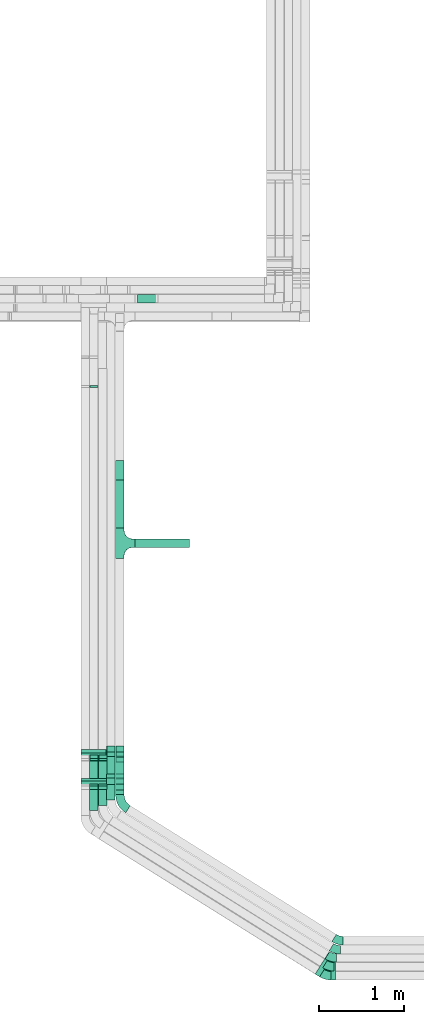
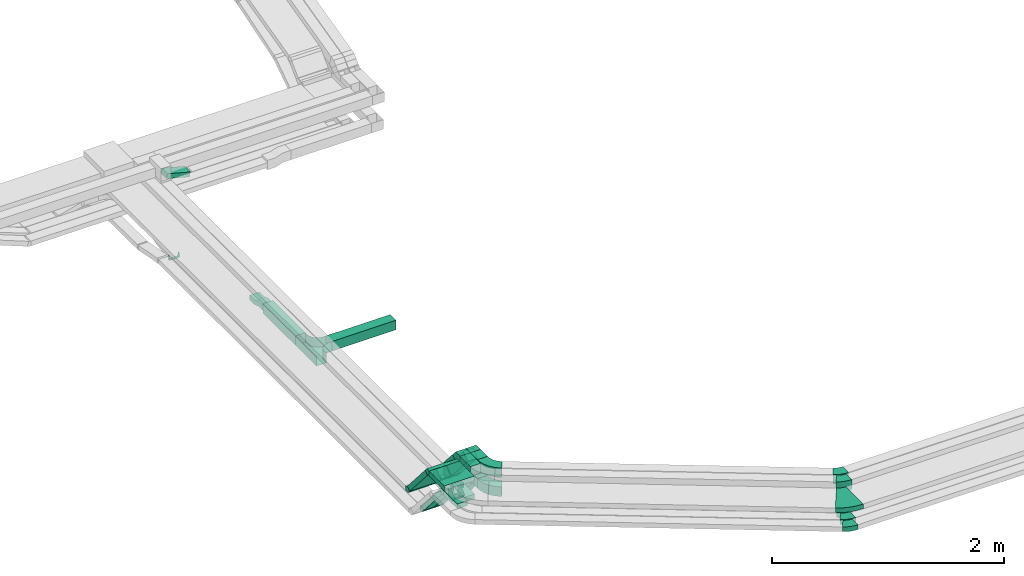
# One storey, part 4 of 14: 23 flow fittings, 15 flow segments.
"""IFC2X3 building model written with IfcOpenShell, lengths in millimetres."""

from ifc_helpers import new_model, entity, si_unit, converted_unit, derived_unit, direction, frame, frame_2d, origin, origin_2d_with_axis, place, context, subcontext, project, spatial, polyline, circle_curve, parameter, trimmed, segment, composite_curve, rectangle, outline, extrude, faceted_brep, source, transform, mapped, material, type_object, type_shapes, element, save


model = new_model("IFC2X3")

# Units and contexts
model_context = context("Model", 3, precision=0.01, world=origin(), true_north=direction((6.12303176911189e-17, 1.0)))
body_context = subcontext(model_context, "Body", "Model", "MODEL_VIEW")
ifc_project = project(units=[si_unit("LENGTHUNIT", "METRE", prefix="MILLI"), si_unit("AREAUNIT", "SQUARE_METRE"), si_unit("VOLUMEUNIT", "CUBIC_METRE"), converted_unit("PLANEANGLEUNIT", "DEGREE", entity("IfcRatioMeasure", 0.0174532925199433), si_unit("PLANEANGLEUNIT", "RADIAN"), dimensions=[0, 0, 0, 0, 0, 0, 0]), si_unit("MASSUNIT", "GRAM", prefix="KILO"), derived_unit("MASSDENSITYUNIT", [(si_unit("MASSUNIT", "GRAM", prefix="KILO"), 1), (si_unit("LENGTHUNIT", "METRE"), -3)]), derived_unit("MOMENTOFINERTIAUNIT", [(si_unit("LENGTHUNIT", "METRE"), 4)]), si_unit("TIMEUNIT", "SECOND"), si_unit("FREQUENCYUNIT", "HERTZ"), si_unit("THERMODYNAMICTEMPERATUREUNIT", "DEGREE_CELSIUS"), derived_unit("THERMALTRANSMITTANCEUNIT", [(si_unit("MASSUNIT", "GRAM", prefix="KILO"), 1), (si_unit("THERMODYNAMICTEMPERATUREUNIT", "KELVIN"), -1), (si_unit("TIMEUNIT", "SECOND"), -3)]), derived_unit("VOLUMETRICFLOWRATEUNIT", [(si_unit("LENGTHUNIT", "METRE"), 3), (si_unit("TIMEUNIT", "SECOND"), -1)]), derived_unit("MASSFLOWRATEUNIT", [(si_unit("MASSUNIT", "GRAM", prefix="KILO"), 1), (si_unit("TIMEUNIT", "SECOND"), -1)]), derived_unit("ROTATIONALFREQUENCYUNIT", [(si_unit("TIMEUNIT", "SECOND"), -1)]), si_unit("ELECTRICCURRENTUNIT", "AMPERE"), si_unit("ELECTRICVOLTAGEUNIT", "VOLT"), si_unit("POWERUNIT", "WATT"), si_unit("FORCEUNIT", "NEWTON", prefix="KILO"), si_unit("ILLUMINANCEUNIT", "LUX"), si_unit("LUMINOUSFLUXUNIT", "LUMEN"), si_unit("LUMINOUSINTENSITYUNIT", "CANDELA"), derived_unit("USERDEFINED", [(si_unit("MASSUNIT", "GRAM", prefix="KILO"), -1), (si_unit("LENGTHUNIT", "METRE"), -2), (si_unit("TIMEUNIT", "SECOND"), 3), (si_unit("LUMINOUSFLUXUNIT", "LUMEN"), 1)]), derived_unit("LINEARVELOCITYUNIT", [(si_unit("LENGTHUNIT", "METRE"), 1), (si_unit("TIMEUNIT", "SECOND"), -1)]), si_unit("PRESSUREUNIT", "PASCAL"), derived_unit("USERDEFINED", [(si_unit("LENGTHUNIT", "METRE"), -2), (si_unit("MASSUNIT", "GRAM", prefix="KILO"), 1), (si_unit("TIMEUNIT", "SECOND"), -2)]), derived_unit("LINEARFORCEUNIT", [(si_unit("MASSUNIT", "GRAM", prefix="KILO"), 1), (si_unit("LENGTHUNIT", "METRE"), 1), (si_unit("TIMEUNIT", "SECOND"), -2), (si_unit("LENGTHUNIT", "METRE"), -1)]), derived_unit("PLANARFORCEUNIT", [(si_unit("MASSUNIT", "GRAM", prefix="KILO"), 1), (si_unit("LENGTHUNIT", "METRE"), 1), (si_unit("TIMEUNIT", "SECOND"), -2), (si_unit("LENGTHUNIT", "METRE"), -2)])], contexts=[model_context])

# Site, building, storey
site_placement = place(None, origin())
site = spatial("IfcSite", under=ifc_project, at=site_placement, CompositionType="ELEMENT")
building_placement = place(site_placement, origin())
building = spatial("IfcBuilding", under=site, at=building_placement, CompositionType="ELEMENT")
storey_placement = place(building_placement, frame((0.0, 0.0, 19800.0)))
storey = spatial("IfcBuildingStorey", under=building, at=storey_placement, CompositionType="ELEMENT", Elevation=19800.0)

# Flow segments
cable_carrier_segment_type = type_object("IfcCableCarrierSegmentType", PredefinedType="CABLETRAYSEGMENT")
flow_segment_1_placement = place(storey_placement, frame((18112.14, 4082.62, 3000.0)))
element("IfcFlowSegment", 1, at=flow_segment_1_placement, inside=storey, type_object=cable_carrier_segment_type, context=body_context, shape_type="SweptSolid", body=[
    extrude(rectangle(XDim=241.620714461309, YDim=99.9999999999989, at=origin_2d_with_axis()), frame((50.0, 120.81, 0.0), z_axis=(0.0, 0.0, 1.0), x_axis=(0.0, 1.0, 0.0)), (0.0, 0.0, 1.0), 49.9999999999973),
])
flow_segment_2_placement = place(storey_placement, frame((18217.14, 4139.25, 3000.0)))
element("IfcFlowSegment", 2, at=flow_segment_2_placement, inside=storey, type_object=cable_carrier_segment_type, context=body_context, shape_type="SweptSolid", body=[
    extrude(rectangle(XDim=184.989638295838, YDim=99.9999999999989, at=origin_2d_with_axis()), frame((50.0, 92.49, 0.0), z_axis=(0.0, 0.0, 1.0), x_axis=(0.0, 1.0, 0.0)), (0.0, 0.0, 1.0), 49.999999999993),
])
flow_segment_3_placement = place(storey_placement, frame((18417.14, 4266.17, 3000.0)))
element("IfcFlowSegment", 3, at=flow_segment_3_placement, inside=storey, type_object=cable_carrier_segment_type, context=body_context, shape_type="SweptSolid", body=[
    extrude(rectangle(XDim=57.0191013239463, YDim=99.9999999999989, at=origin_2d_with_axis()), frame((50.0, 28.51, 0.0), z_axis=(0.0, 0.0, 1.0), x_axis=(0.0, 1.0, 0.0)), (0.0, 0.0, 1.0), 100.000000000008),
])
for number, where in (
    (4, (18112.14, 4355.16, 2631.29)),
    (5, (18217.14, 4355.16, 2631.29)),
):
    element("IfcFlowSegment", number, at=place(storey_placement, frame(where)), inside=storey, type_object=cable_carrier_segment_type, context=body_context, shape_type="SweptSolid", body=[
        extrude(rectangle(XDim=49.999999999999, YDim=99.9999999999989, at=origin_2d_with_axis()), frame((50.0, 327.13, 16.4), z_axis=(0.0, -0.656059028990503, 0.754709580222776), x_axis=(0.0, 0.754709580222776, 0.656059028990503)), (0.0, 0.0, 1.0), 469.87530923093),
    ])
flow_segment_4_placement = place(storey_placement, frame((18417.14, 4372.97, 2657.08)))
element("IfcFlowSegment", 6, at=flow_segment_4_placement, inside=storey, type_object=cable_carrier_segment_type, context=body_context, shape_type="SweptSolid", body=[
    extrude(rectangle(XDim=99.9999999999987, YDim=99.9999999999989, at=origin_2d_with_axis()), frame((50.0, 316.1, 32.8), z_axis=(0.0, -0.656059028990498, 0.75470958022278), x_axis=(0.0, 0.75470958022278, 0.656059028990498)), (0.0, 0.0, 1.0), 424.302683677664),
])
flow_segment_5_placement = place(storey_placement, frame((18007.14, 4128.05, 3200.0)))
element("IfcFlowSegment", 7, at=flow_segment_5_placement, inside=storey, type_object=cable_carrier_segment_type, context=body_context, shape_type="SweptSolid", body=[
    extrude(rectangle(XDim=259.517993750342, YDim=300.000000000001, at=origin_2d_with_axis()), frame((150.0, 129.76, 0.0), z_axis=(0.0, 0.0, 1.0), x_axis=(0.0, 1.0, 0.0)), (0.0, 0.0, 1.0), 49.9999999999973),
])
flow_segment_6_placement = place(storey_placement, frame((18007.14, 4418.49, 2831.29)))
element("IfcFlowSegment", 8, at=flow_segment_6_placement, inside=storey, type_object=cable_carrier_segment_type, context=body_context, shape_type="SweptSolid", body=[
    extrude(rectangle(XDim=49.999999999999, YDim=300.000000000001, at=origin_2d_with_axis()), frame((150.0, 327.13, 16.4), z_axis=(0.0, -0.656059028990503, 0.754709580222776), x_axis=(0.0, 0.754709580222776, 0.656059028990503)), (0.0, 0.0, 1.0), 469.875309230929),
])
flow_segment_7_placement = place(storey_placement, frame((18312.14, 4205.1, 3200.0)))
element("IfcFlowSegment", 9, at=flow_segment_7_placement, inside=storey, type_object=cable_carrier_segment_type, context=body_context, shape_type="SweptSolid", body=[
    extrude(rectangle(XDim=181.412475285859, YDim=99.9999999999989, at=origin_2d_with_axis()), frame((50.0, 90.71, 0.0), z_axis=(0.0, 0.0, 1.0), x_axis=(0.0, 1.0, 0.0)), (0.0, 0.0, 1.0), 100.000000000003),
])
flow_segment_8_placement = place(storey_placement, frame((18312.14, 4436.3, 2857.08)))
element("IfcFlowSegment", 10, at=flow_segment_8_placement, inside=storey, type_object=cable_carrier_segment_type, context=body_context, shape_type="SweptSolid", body=[
    extrude(rectangle(XDim=99.9999999999979, YDim=99.9999999999989, at=origin_2d_with_axis()), frame((50.0, 316.1, 32.8), z_axis=(0.0, -0.656059028990503, 0.754709580222776), x_axis=(0.0, 0.754709580222776, 0.656059028990503)), (0.0, 0.0, 1.0), 424.302683677666),
])
flow_segment_9_placement = place(storey_placement, frame((18417.14, 4266.17, 3200.0)))
element("IfcFlowSegment", 11, at=flow_segment_9_placement, inside=storey, type_object=cable_carrier_segment_type, context=body_context, shape_type="SweptSolid", body=[
    extrude(rectangle(XDim=120.344185412181, YDim=99.9999999999989, at=origin_2d_with_axis()), frame((50.0, 60.17, 0.0), z_axis=(0.0, 0.0, 1.0), x_axis=(0.0, 1.0, 0.0)), (0.0, 0.0, 1.0), 100.000000000008),
])
flow_segment_10_placement = place(storey_placement, frame((18417.14, 4436.3, 2857.08)))
element("IfcFlowSegment", 12, at=flow_segment_10_placement, inside=storey, type_object=cable_carrier_segment_type, context=body_context, shape_type="SweptSolid", body=[
    extrude(rectangle(XDim=99.9999999999979, YDim=99.9999999999989, at=origin_2d_with_axis()), frame((50.0, 316.1, 32.8), z_axis=(0.0, -0.656059028990503, 0.754709580222776), x_axis=(0.0, 0.754709580222776, 0.656059028990503)), (0.0, 0.0, 1.0), 424.302683677666),
])
flow_segment_11_placement = place(storey_placement, frame((18647.14, 7173.75, 2600.0)))
element("IfcFlowSegment", 13, at=flow_segment_11_placement, inside=storey, type_object=cable_carrier_segment_type, context=body_context, shape_type="SweptSolid", body=[
    extrude(rectangle(XDim=640.000000000004, YDim=100.000000000001, at=origin_2d_with_axis()), frame((320.0, 50.0, 0.0)), (0.0, 0.0, 1.0), 100.000000000003),
])
flow_segment_12_placement = place(storey_placement, frame((18417.14, 7403.75, 2600.0)))
element("IfcFlowSegment", 14, at=flow_segment_12_placement, inside=storey, type_object=cable_carrier_segment_type, context=body_context, shape_type="SweptSolid", body=[
    extrude(rectangle(XDim=560.199844800006, YDim=99.9999999999989, at=origin_2d_with_axis()), frame((50.0, 280.1, 0.0), z_axis=(0.0, 0.0, 1.0), x_axis=(0.0, 1.0, 0.0)), (0.0, 0.0, 1.0), 100.000000000003),
])
flow_segment_13_placement = place(storey_placement, frame((18659.43, 10049.82, 2604.02)))
element("IfcFlowSegment", 15, at=flow_segment_13_placement, inside=storey, type_object=cable_carrier_segment_type, context=body_context, shape_type="SweptSolid", body=[
    extrude(rectangle(XDim=49.9999999999963, YDim=99.9999999999989, at=origin_2d_with_axis()), frame((6.47, 50.0, 85.1), z_axis=(0.965925826289085, 0.0, -0.258819045102459), x_axis=(0.258819045102459, 0.0, 0.965925826289085)), (0.0, 0.0, 1.0), 235.518225265324),
])

# Flow fittings
ifc_material = material()
cable_carrier_fitting_type_1 = type_object("IfcCableCarrierFittingType", PredefinedType="NOTDEFINED", material=ifc_material)
shared_shape_1 = source(origin(), body_context, "Body", "SweptSolid", [
    extrude(outline(polyline([(-115.0, 12.5), (-115.0, -37.5), (-38.33, -37.5), (38.33, -12.5), (115.0, -12.5), (115.0, 37.5), (38.33, 37.5), (-38.33, 12.5), (-115.0, 12.5)])), frame((115.0, -50.0, 12.5), z_axis=(0.0, -1.0, 0.0), x_axis=(1.0, 0.0, 0.0)), (0.0, 0.0, -1.0), 99.9999999999999),
])
type_shapes(cable_carrier_fitting_type_1, [shared_shape_1])
flow_fitting_1_placement = place(storey_placement, frame((18467.14, 8193.95, 2625.0), z_axis=(0.0, 0.0, 1.0), x_axis=(0.0, -1.0, 0.0)))
element("IfcFlowFitting", 16, at=flow_fitting_1_placement, inside=storey, type_object=cable_carrier_fitting_type_1, material=ifc_material, Name="470_DKC_S5_adapter", context=body_context, shape_type="MappedRepresentation", body=[
    mapped(shared_shape_1, transform((0.0, 0.0, 0.0), scale=1.0)),
])
cable_carrier_fitting_type_2 = type_object("IfcCableCarrierFittingType", PredefinedType="NOTDEFINED", material=ifc_material)
shared_shape_2 = source(origin(), body_context, "Body", "Brep", [
    faceted_brep([(-30.06, -25.0, 50.0), (-30.06, 25.0, 50.0), (-30.06, 25.0, 47.46), (-30.06, -22.46, 47.46), (-30.06, -22.46, -47.46), (-30.06, 25.0, -47.46), (-30.06, 25.0, -50.0), (-30.06, -25.0, -50.0), (38.59, 6.29, 50.0), (38.59, 6.29, -50.0), (0.86, 39.09, -50.0), (0.86, 39.09, -47.46), (36.68, 7.96, -47.46), (36.68, 7.96, 47.46), (0.86, 39.09, 47.46), (0.86, 39.09, 50.0), (11.39, -25.0, 50.0), (-11.39, 25.0, 50.0), (-11.39, 25.0, 47.46), (10.24, -22.46, 47.46), (10.24, -22.46, -47.46), (-11.39, 25.0, -47.46), (-11.39, 25.0, -50.0), (11.39, -25.0, -50.0)], [[[0, 1, 2, 3, 4, 5, 6, 7]], [[8, 9, 10, 11, 12, 13, 14, 15]], [[1, 0, 16, 8, 15, 17]], [[2, 1, 17, 18]], [[3, 2, 18, 14, 13, 19]], [[4, 3, 19, 20]], [[5, 4, 20, 12, 11, 21]], [[6, 5, 21, 22]], [[7, 6, 22, 10, 9, 23]], [[0, 7, 23, 16]], [[18, 17, 15, 14]], [[20, 19, 13, 12]], [[22, 21, 11, 10]], [[16, 23, 9, 8]]]),
])
type_shapes(cable_carrier_fitting_type_2, [shared_shape_2])
for number, where, z_axis, x_axis in (
    (17, (18162.14, 4354.3, 3025.0), (1.0, 0.0, 0.0), (0.0, -0.656059028990493, 0.754709580222785)),
    (18, (18267.14, 4354.3, 3025.0), (1.0, 0.0, 0.0), (0.0, -0.656059028990493, 0.754709580222785)),
    (19, (18267.14, 4702.02, 2625.0), (1.0, 0.0, 0.0), (0.0, 0.656059028990493, -0.754709580222785)),
    (20, (18162.14, 4702.02, 2625.0), (1.0, 0.0, 0.0), (0.0, 0.656059028990493, -0.754709580222785)),
):
    element("IfcFlowFitting", number, at=place(storey_placement, frame(where, z_axis=z_axis, x_axis=x_axis)), inside=storey, type_object=cable_carrier_fitting_type_2, material=ifc_material, context=body_context, shape_type="MappedRepresentation", body=[
        mapped(shared_shape_2, transform((0.0, 0.0, 0.0), scale=1.0)),
    ])
cable_carrier_fitting_type_3 = type_object("IfcCableCarrierFittingType", PredefinedType="NOTDEFINED", material=ifc_material)
shared_shape_3 = source(origin(), body_context, "Body", "Brep", [
    faceted_brep([(-52.85, -50.0, 50.0), (-52.85, 50.0, 50.0), (-52.85, 50.0, 47.46), (-52.85, -47.46, 47.46), (-52.85, -47.46, -47.46), (-52.85, 50.0, -47.46), (-52.85, 50.0, -50.0), (-52.85, -50.0, -50.0), (72.41, 7.08, 50.0), (72.41, 7.08, -50.0), (-3.06, 72.69, -50.0), (-3.06, 72.69, -47.46), (70.49, 8.75, -47.46), (70.49, 8.75, 47.46), (-3.06, 72.69, 47.46), (-3.06, 72.69, 50.0), (22.79, -50.0, 50.0), (-22.79, 50.0, 50.0), (-22.79, 50.0, 47.46), (21.63, -47.46, 47.46), (21.63, -47.46, -47.46), (-22.79, 50.0, -47.46), (-22.79, 50.0, -50.0), (22.79, -50.0, -50.0)], [[[0, 1, 2, 3, 4, 5, 6, 7]], [[8, 9, 10, 11, 12, 13, 14, 15]], [[1, 0, 16, 8, 15, 17]], [[2, 1, 17, 18]], [[3, 2, 18, 14, 13, 19]], [[4, 3, 19, 20]], [[5, 4, 20, 12, 11, 21]], [[6, 5, 21, 22]], [[7, 6, 22, 10, 9, 23]], [[0, 7, 23, 16]], [[18, 17, 15, 14]], [[20, 19, 13, 12]], [[22, 21, 11, 10]], [[16, 23, 9, 8]]]),
])
type_shapes(cable_carrier_fitting_type_3, [shared_shape_3])
for number, where, z_axis, x_axis in (
    (21, (18467.14, 4376.04, 3050.0), (1.0, 0.0, 0.0), (0.0, -0.656059028990495, 0.754709580222783)),
    (22, (18362.14, 4439.36, 3250.0), (1.0, 0.0, 0.0), (0.0, -0.656059028990503, 0.754709580222776)),
    (23, (18362.14, 4787.08, 2850.0), (1.0, 0.0, 0.0), (0.0, 0.656059028990503, -0.754709580222776)),
    (24, (18467.14, 4439.36, 3250.0), (1.0, 0.0, 0.0), (0.0, -0.656059028990503, 0.754709580222776)),
    (25, (18467.14, 4787.08, 2850.0), (1.0, 0.0, 0.0), (0.0, 0.656059028990503, -0.754709580222776)),
    (26, (18467.14, 4723.75, 2650.0), (1.0, 0.0, 0.0), (0.0, 0.656059028990495, -0.754709580222783)),
):
    element("IfcFlowFitting", number, at=place(storey_placement, frame(where, z_axis=z_axis, x_axis=x_axis)), inside=storey, type_object=cable_carrier_fitting_type_3, material=ifc_material, context=body_context, shape_type="MappedRepresentation", body=[
        mapped(shared_shape_3, transform((0.0, 0.0, 0.0), scale=1.0)),
    ])
cable_carrier_fitting_type_4 = type_object("IfcCableCarrierFittingType", PredefinedType="NOTDEFINED", material=ifc_material)
shared_shape_4 = source(origin(), body_context, "Body", "Brep", [
    faceted_brep([(-30.06, -25.0, 150.0), (-30.06, 25.0, 150.0), (-30.06, 25.0, 147.46), (-30.06, -22.46, 147.46), (-30.06, -22.46, -147.46), (-30.06, 25.0, -147.46), (-30.06, 25.0, -150.0), (-30.06, -25.0, -150.0), (38.59, 6.29, 150.0), (38.59, 6.29, -150.0), (0.86, 39.09, -150.0), (0.86, 39.09, -147.46), (36.68, 7.96, -147.46), (36.68, 7.96, 147.46), (0.86, 39.09, 147.46), (0.86, 39.09, 150.0), (11.39, -25.0, 150.0), (-11.39, 25.0, 150.0), (-11.39, 25.0, 147.46), (10.24, -22.46, 147.46), (10.24, -22.46, -147.46), (-11.39, 25.0, -147.46), (-11.39, 25.0, -150.0), (11.39, -25.0, -150.0)], [[[0, 1, 2, 3, 4, 5, 6, 7]], [[8, 9, 10, 11, 12, 13, 14, 15]], [[1, 0, 16, 8, 15, 17]], [[2, 1, 17, 18]], [[3, 2, 18, 14, 13, 19]], [[4, 3, 19, 20]], [[5, 4, 20, 12, 11, 21]], [[6, 5, 21, 22]], [[7, 6, 22, 10, 9, 23]], [[0, 7, 23, 16]], [[18, 17, 15, 14]], [[20, 19, 13, 12]], [[22, 21, 11, 10]], [[16, 23, 9, 8]]]),
])
type_shapes(cable_carrier_fitting_type_4, [shared_shape_4])
for number, where, z_axis, x_axis in (
    (27, (18157.14, 4417.63, 3225.0), (-1.0, 0.0, 0.0), (0.0, 1.0, 0.0)),
    (28, (18157.14, 4765.34, 2825.0), (1.0, 0.0, 0.0), (0.0, 0.656059028990504, -0.754709580222775)),
):
    element("IfcFlowFitting", number, at=place(storey_placement, frame(where, z_axis=z_axis, x_axis=x_axis)), inside=storey, type_object=cable_carrier_fitting_type_4, material=ifc_material, context=body_context, shape_type="MappedRepresentation", body=[
        mapped(shared_shape_4, transform((0.0, 0.0, 0.0), scale=1.0)),
    ])
cable_carrier_fitting_type_5 = type_object("IfcCableCarrierFittingType", PredefinedType="NOTDEFINED", material=ifc_material)
shared_shape_5 = source(origin(), body_context, "Body", "Brep", [
    faceted_brep([(-53.41, -124.12, 50.0), (-50.0, -150.0, 50.0), (-50.0, -180.0, 50.0), (-49.2, -180.0, 50.0), (-49.2, -150.0, 50.0), (-52.63, -123.91, 50.0), (-62.7, -99.6, 50.0), (-78.72, -78.72, 50.0), (-99.6, -62.7, 50.0), (-123.91, -52.63, 50.0), (-150.0, -49.2, 50.0), (-180.0, -49.2, 50.0), (-180.0, -50.0, 50.0), (-150.0, -50.0, 50.0), (-124.12, -53.41, 50.0), (-100.0, -63.4, 50.0), (-79.29, -79.29, 50.0), (-63.4, -100.0, 50.0), (180.0, -50.0, 50.0), (180.0, -49.2, 50.0), (150.0, -49.2, 50.0), (123.91, -52.63, 50.0), (99.6, -62.7, 50.0), (78.72, -78.72, 50.0), (62.7, -99.6, 50.0), (52.63, -123.91, 50.0), (49.2, -150.0, 50.0), (49.2, -180.0, 50.0), (50.0, -180.0, 50.0), (50.0, -150.0, 50.0), (53.41, -124.12, 50.0), (63.4, -100.0, 50.0), (79.29, -79.29, 50.0), (100.0, -63.4, 50.0), (124.12, -53.41, 50.0), (150.0, -50.0, 50.0), (180.0, 49.2, 50.0), (180.0, 50.0, 50.0), (-180.0, 50.0, 50.0), (-180.0, 49.2, 50.0), (-180.0, -50.0, -50.0), (-180.0, 50.0, -50.0), (180.0, 50.0, -50.0), (180.0, -50.0, -50.0), (150.0, -50.0, -50.0), (124.12, -53.41, -50.0), (100.0, -63.4, -50.0), (79.29, -79.29, -50.0), (63.4, -100.0, -50.0), (53.41, -124.12, -50.0), (50.0, -150.0, -50.0), (50.0, -180.0, -50.0), (-50.0, -180.0, -50.0), (-50.0, -150.0, -50.0), (-53.41, -124.12, -50.0), (-63.4, -100.0, -50.0), (-79.29, -79.29, -50.0), (-100.0, -63.4, -50.0), (-124.12, -53.41, -50.0), (-150.0, -50.0, -50.0), (-50.0, -150.0, -49.2), (49.2, -180.0, -49.2), (-49.2, -180.0, -49.2), (-49.2, -150.0, -49.2), (-150.0, -49.2, -49.2), (-180.0, -49.2, -49.2), (180.0, -49.2, -49.2), (150.0, -49.2, -49.2), (-180.0, 49.2, -49.2), (-150.0, -50.0, -49.2), (150.0, -50.0, -49.2), (180.0, 49.2, -49.2), (49.2, -150.0, -49.2), (50.0, -150.0, -49.2), (-123.91, -52.63, -49.2), (-99.6, -62.7, -49.2), (-78.72, -78.72, -49.2), (-62.7, -99.6, -49.2), (-52.63, -123.91, -49.2), (52.63, -123.91, -49.2), (62.7, -99.6, -49.2), (78.72, -78.72, -49.2), (99.6, -62.7, -49.2), (123.91, -52.63, -49.2)], [[[0, 1, 2, 3, 4, 5, 6, 7, 8, 9, 10, 11, 12, 13, 14, 15, 16, 17]], [[18, 19, 20, 21, 22, 23, 24, 25, 26, 27, 28, 29, 30, 31, 32, 33, 34, 35]], [[36, 37, 38, 39]], [[40, 41, 42, 43, 44, 45, 46, 47, 48, 49, 50, 51, 52, 53, 54, 55, 56, 57, 58, 59]], [[2, 1, 60, 53, 52]], [[3, 2, 52, 51, 28, 27, 61, 62]], [[4, 3, 62, 63]], [[11, 10, 64, 65]], [[20, 19, 66, 67]], [[39, 38, 41, 40, 12, 11, 65, 68]], [[13, 12, 40, 59, 69]], [[18, 35, 70, 44, 43]], [[19, 18, 43, 42, 37, 36, 71, 66]], [[27, 26, 72, 61]], [[29, 28, 51, 50, 73]], [[38, 37, 42, 41]], [[36, 39, 68, 71]], [[68, 65, 64, 74, 75, 76, 77, 78, 63, 62, 61, 72, 79, 80, 81, 82, 83, 67, 66, 71]], [[14, 13, 69, 59, 58]], [[15, 14, 58, 57]], [[57, 56, 16, 15]], [[17, 16, 56, 55]], [[0, 17, 55, 54]], [[1, 0, 54, 53, 60]], [[5, 78, 77, 6]], [[6, 77, 76, 7]], [[63, 78, 5, 4]], [[8, 75, 74, 9]], [[9, 74, 64, 10]], [[7, 76, 75, 8]], [[21, 83, 82, 22]], [[22, 82, 81, 23]], [[67, 83, 21, 20]], [[24, 80, 79, 25]], [[25, 79, 72, 26]], [[23, 81, 80, 24]], [[30, 29, 73, 50, 49]], [[31, 30, 49, 48]], [[32, 31, 48, 47]], [[34, 33, 46, 45]], [[34, 45, 44, 70, 35]], [[46, 33, 32, 47]]]),
])
type_shapes(cable_carrier_fitting_type_5, [shared_shape_5])
flow_fitting_2_placement = place(storey_placement, frame((18467.14, 7223.75, 2650.0), z_axis=(0.0, 0.0, 1.0), x_axis=(0.0, 1.0, 0.0)))
element("IfcFlowFitting", 29, at=flow_fitting_2_placement, inside=storey, type_object=cable_carrier_fitting_type_5, material=ifc_material, Name="470_DKC_S5_T", context=body_context, shape_type="MappedRepresentation", body=[
    mapped(shared_shape_5, transform((0.0, 0.0, 0.0), scale=1.0)),
])
cable_carrier_fitting_type_6 = type_object("IfcCableCarrierFittingType", PredefinedType="NOTDEFINED", material=ifc_material)
shared_shape_6 = source(origin(), body_context, "Body", "Brep", [
    faceted_brep([(-10.24, -25.0, 50.0), (-10.24, 25.0, 50.0), (-10.24, 25.0, 47.46), (-10.24, -22.46, 47.46), (-10.24, -22.46, -47.46), (-10.24, 25.0, -47.46), (-10.24, 25.0, -50.0), (-10.24, -25.0, -50.0), (14.78, -22.62, 50.0), (14.78, -22.62, -50.0), (5.33, 26.48, -50.0), (5.33, 26.48, -47.46), (14.3, -20.12, -47.46), (14.3, -20.12, 47.46), (5.33, 26.48, 47.46), (5.33, 26.48, 50.0), (2.38, -25.0, 50.0), (-2.38, 25.0, 50.0), (-2.38, 25.0, 47.46), (2.14, -22.46, 47.46), (2.14, -22.46, -47.46), (-2.38, 25.0, -47.46), (-2.38, 25.0, -50.0), (2.38, -25.0, -50.0)], [[[0, 1, 2, 3, 4, 5, 6, 7]], [[8, 9, 10, 11, 12, 13, 14, 15]], [[1, 0, 16, 8, 15, 17]], [[2, 1, 17, 18]], [[3, 2, 18, 14, 13, 19]], [[4, 3, 19, 20]], [[5, 4, 20, 12, 11, 21]], [[6, 5, 21, 22]], [[7, 6, 22, 10, 9, 23]], [[0, 7, 23, 16]], [[18, 17, 15, 14]], [[20, 19, 13, 12]], [[22, 21, 11, 10]], [[16, 23, 9, 8]]]),
])
type_shapes(cable_carrier_fitting_type_6, [shared_shape_6])
flow_fitting_3_placement = place(storey_placement, frame((18162.14, 9062.02, 2625.0), z_axis=(1.0, 0.0, 0.0), x_axis=(0.0, 1.0, 0.0)))
element("IfcFlowFitting", 30, at=flow_fitting_3_placement, inside=storey, type_object=cable_carrier_fitting_type_6, material=ifc_material, context=body_context, shape_type="MappedRepresentation", body=[
    mapped(shared_shape_6, transform((0.0, 0.0, 0.0), scale=1.0)),
])
cable_carrier_fitting_type_7 = type_object("IfcCableCarrierFittingType", Name="470_DKC_S5_Variable Angle Elbow 0-45:-", PredefinedType="NOTDEFINED", material=ifc_material)
shared_shape_7 = source(origin(), body_context, "Body", "SweptSolid", [
    extrude(outline(composite_curve([segment(polyline([(-53.95, -65.33), (-52.95, -65.33)]), True, "CONTINUOUS"), segment(trimmed(circle_curve(frame_2d((-52.95, 184.67), x_axis=(0.0, -1.0)), 250.0), [parameter(0.0)], [parameter(32.0000000000001)], True, "PARAMETER"), True, "CONTINUOUS"), segment(polyline([(79.53, -27.34), (80.37, -26.81)]), True, "CONTINUOUS"), segment(polyline([(80.37, -26.81), (27.38, 58.0)]), True, "CONTINUOUS"), segment(polyline([(27.38, 58.0), (26.53, 57.47)]), True, "CONTINUOUS"), segment(trimmed(circle_curve(frame_2d((-52.95, 184.67), x_axis=(0.0, -1.0)), 150.0), [parameter(0.0)], [parameter(32.0000000000001)], True, "PARAMETER"), False, "CONTINUOUS"), segment(polyline([(-52.95, 34.67), (-53.95, 34.67)]), True, "CONTINUOUS"), segment(polyline([(-53.95, 34.67), (-53.95, -65.33)]), True, "CONTINUOUS")], self_intersect=False)), frame((-4.4, 15.33, -50.0)), (0.0, 0.0, 1.0), 100.0),
])
type_shapes(cable_carrier_fitting_type_7, [shared_shape_7])
for number, where, z_axis, x_axis, name in (
    (31, (21004.24, 2442.27, 3250.0), (0.0, 0.0, 1.0), (0.848048096156423, -0.52991926423321, 0.0), "470_DKC_S5_Variable Angle Elbow 0-45:-"),
    (32, (21034.57, 2550.0, 3250.0), (0.0, 0.0, 1.0), (0.848048096156423, -0.52991926423321, 0.0), "470_DKC_S5_Variable Angle Elbow 0-45:-"),
):
    element("IfcFlowFitting", number, at=place(storey_placement, frame(where, z_axis=z_axis, x_axis=x_axis)), inside=storey, type_object=cable_carrier_fitting_type_7, material=ifc_material, Name=name, ObjectType="470_DKC_S5_Variable Angle Elbow 0-45:-", context=body_context, shape_type="MappedRepresentation", body=[
        mapped(shared_shape_7, transform((0.0, 0.0, 0.0), scale=1.0)),
    ])
cable_carrier_fitting_type_8 = type_object("IfcCableCarrierFittingType", Name="470_DKC_S5_Variable Angle Elbow 0-45:-", PredefinedType="NOTDEFINED", material=ifc_material)
shared_shape_8 = source(origin(), body_context, "Body", "SweptSolid", [
    extrude(outline(composite_curve([segment(polyline([(-53.95, -65.33), (-52.95, -65.33)]), True, "CONTINUOUS"), segment(trimmed(circle_curve(frame_2d((-52.95, 184.67), x_axis=(0.0, -1.0)), 250.0), [parameter(0.0)], [parameter(32.0000000000003)], True, "PARAMETER"), True, "CONTINUOUS"), segment(polyline([(79.53, -27.34), (80.37, -26.81)]), True, "CONTINUOUS"), segment(polyline([(80.37, -26.81), (27.38, 58.0)]), True, "CONTINUOUS"), segment(polyline([(27.38, 58.0), (26.53, 57.47)]), True, "CONTINUOUS"), segment(trimmed(circle_curve(frame_2d((-52.95, 184.67), x_axis=(0.0, -1.0)), 150.0), [parameter(0.0)], [parameter(32.0000000000003)], True, "PARAMETER"), False, "CONTINUOUS"), segment(polyline([(-52.95, 34.67), (-53.95, 34.67)]), True, "CONTINUOUS"), segment(polyline([(-53.95, 34.67), (-53.95, -65.33)]), True, "CONTINUOUS")], self_intersect=False)), frame((-4.4, 15.33, -25.0)), (0.0, 0.0, 1.0), 50.0),
])
type_shapes(cable_carrier_fitting_type_8, [shared_shape_8])
for number, where, z_axis, x_axis, name in (
    (33, (20955.9, 2347.27, 3025.0), (0.0, 0.0, 1.0), (0.848048096156423, -0.52991926423321, 0.0), "470_DKC_S5_Variable Angle Elbow 0-45:-"),
    (34, (20928.3, 2242.27, 3025.0), (0.0, 0.0, 1.0), (0.848048096156423, -0.52991926423321, 0.0), "470_DKC_S5_Variable Angle Elbow 0-45:-"),
    (35, (20891.69, 2137.27, 3025.0), (0.0, 0.0, 1.0), (0.848048096156423, -0.52991926423321, 0.0), "470_DKC_S5_Variable Angle Elbow 0-45:-"),
):
    element("IfcFlowFitting", number, at=place(storey_placement, frame(where, z_axis=z_axis, x_axis=x_axis)), inside=storey, type_object=cable_carrier_fitting_type_8, material=ifc_material, Name=name, ObjectType="470_DKC_S5_Variable Angle Elbow 0-45:-", context=body_context, shape_type="MappedRepresentation", body=[
        mapped(shared_shape_8, transform((0.0, 0.0, 0.0), scale=1.0)),
    ])
cable_carrier_fitting_type_9 = type_object("IfcCableCarrierFittingType", Name="470_DKC_S5_Variable Angle Elbow 0-45:-", PredefinedType="NOTDEFINED", material=ifc_material)
shared_shape_9 = source(origin(), body_context, "Body", "SweptSolid", [
    extrude(outline(composite_curve([segment(polyline([(-80.45, -172.93), (-79.45, -172.93)]), True, "CONTINUOUS"), segment(trimmed(circle_curve(frame_2d((-79.45, 277.07), x_axis=(0.0, -1.0)), 450.0), [parameter(0.0)], [parameter(32.0000000000003)], True, "PARAMETER"), True, "CONTINUOUS"), segment(polyline([(159.01, -104.55), (159.86, -104.02)]), True, "CONTINUOUS"), segment(polyline([(159.86, -104.02), (0.89, 150.4)]), True, "CONTINUOUS"), segment(polyline([(0.89, 150.4), (0.04, 149.87)]), True, "CONTINUOUS"), segment(trimmed(circle_curve(frame_2d((-79.45, 277.07), x_axis=(0.0, -1.0)), 150.0), [parameter(0.0)], [parameter(32.0000000000003)], True, "PARAMETER"), False, "CONTINUOUS"), segment(polyline([(-79.45, 127.07), (-80.45, 127.07)]), True, "CONTINUOUS"), segment(polyline([(-80.45, 127.07), (-80.45, -172.93)]), True, "CONTINUOUS")], self_intersect=False)), frame((-6.57, 22.93, -25.0)), (0.0, 0.0, 1.0), 49.9999999999987),
])
type_shapes(cable_carrier_fitting_type_9, [shared_shape_9])
flow_fitting_4_placement = place(storey_placement, frame((20915.3, 2237.27, 3225.0), z_axis=(0.0, 0.0, 1.0), x_axis=(0.848048096156423, -0.529919264233209, 0.0)))
element("IfcFlowFitting", 36, at=flow_fitting_4_placement, inside=storey, type_object=cable_carrier_fitting_type_9, material=ifc_material, Name="470_DKC_S5_Variable Angle Elbow 0-45:-", ObjectType="470_DKC_S5_Variable Angle Elbow 0-45:-", context=body_context, shape_type="MappedRepresentation", body=[
    mapped(shared_shape_9, transform((0.0, 0.0, 0.0), scale=1.0)),
])
cable_carrier_fitting_type_10 = type_object("IfcCableCarrierFittingType", Name="470_DKC_S5_Variable Angle Elbow 0-45:-", PredefinedType="NOTDEFINED", material=ifc_material)
shared_shape_10 = source(origin(), body_context, "Body", "SweptSolid", [
    extrude(outline(composite_curve([segment(polyline([(-85.69, -97.22), (-84.69, -97.22)]), True, "CONTINUOUS"), segment(trimmed(circle_curve(frame_2d((-84.69, 152.78), x_axis=(0.0, -1.0)), 250.0), [parameter(0.0)], [parameter(57.9999999999999)], True, "PARAMETER"), True, "CONTINUOUS"), segment(polyline([(127.32, 20.3), (127.85, 21.15)]), True, "CONTINUOUS"), segment(polyline([(127.85, 21.15), (43.05, 74.14)]), True, "CONTINUOUS"), segment(polyline([(43.05, 74.14), (42.52, 73.29)]), True, "CONTINUOUS"), segment(trimmed(circle_curve(frame_2d((-84.69, 152.78), x_axis=(0.0, -1.0)), 150.0), [parameter(0.0)], [parameter(57.9999999999999)], True, "PARAMETER"), False, "CONTINUOUS"), segment(polyline([(-84.69, 2.78), (-85.69, 2.78)]), True, "CONTINUOUS"), segment(polyline([(-85.69, 2.78), (-85.69, -97.22)]), True, "CONTINUOUS")], self_intersect=False)), frame((-26.17, 47.22, -50.0)), (0.0, 0.0, 1.0), 100.0),
])
type_shapes(cable_carrier_fitting_type_10, [shared_shape_10])
for number, where, z_axis, x_axis, name in (
    (37, (18467.14, 4154.3, 3050.0), (0.0, 0.0, 1.0), (0.0, -1.0, 0.0), "470_DKC_S5_Variable Angle Elbow 0-45:-"),
    (38, (18467.14, 4154.3, 3250.0), (0.0, 0.0, 1.0), (0.0, -1.0, 0.0), "470_DKC_S5_Variable Angle Elbow 0-45:-"),
):
    element("IfcFlowFitting", number, at=place(storey_placement, frame(where, z_axis=z_axis, x_axis=x_axis)), inside=storey, type_object=cable_carrier_fitting_type_10, material=ifc_material, Name=name, ObjectType="470_DKC_S5_Variable Angle Elbow 0-45:-", context=body_context, shape_type="MappedRepresentation", body=[
        mapped(shared_shape_10, transform((0.0, 0.0, 0.0), scale=1.0)),
    ])

save(model, "model.ifc")
